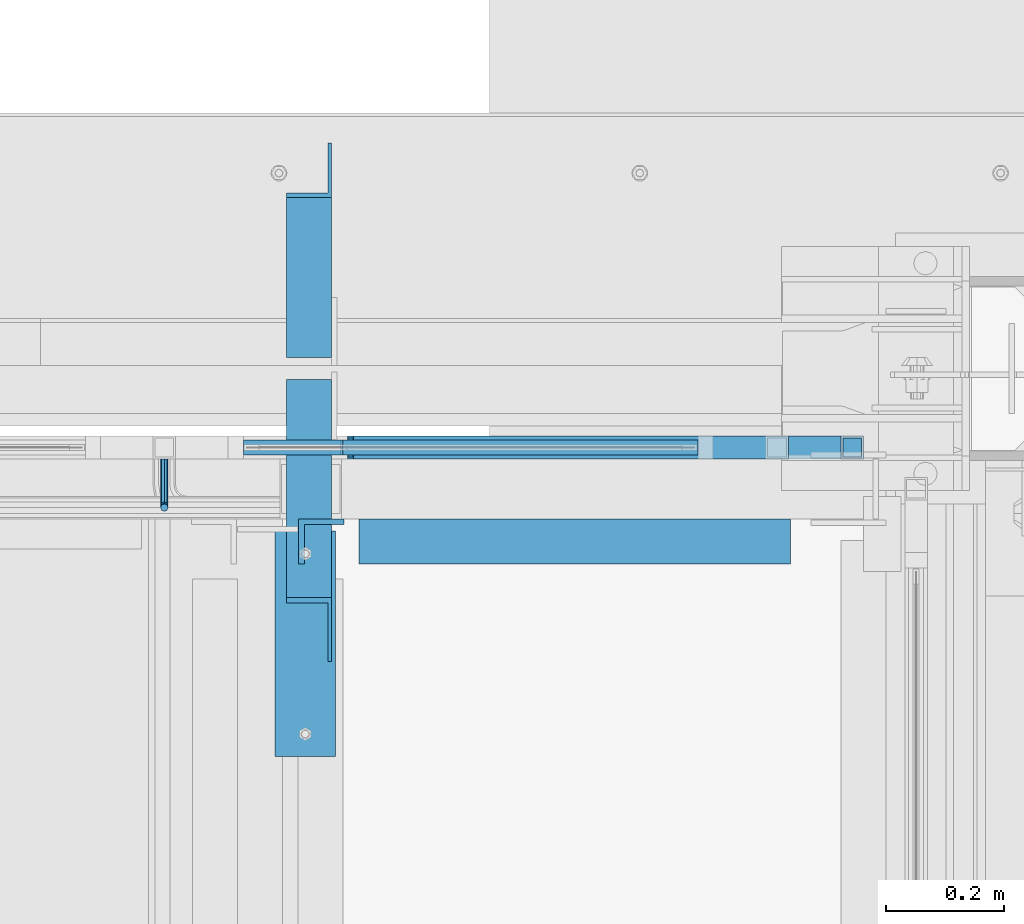
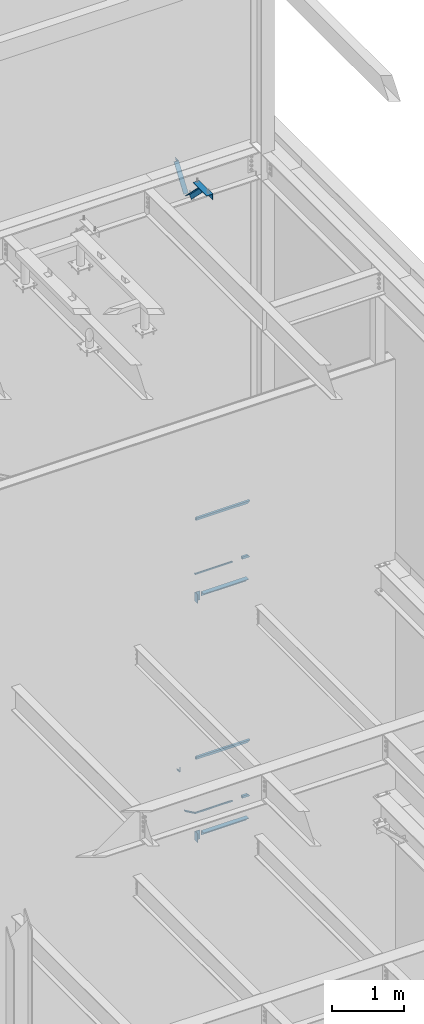
# One storey, part 951 of 1179: 10 beams, 5 members, 7 elements without a shape of their own.
"""IFC2X3 building model written with IfcOpenShell, lengths in millimetres."""

from ifc_helpers import new_model, si_unit, frame, origin_with_axes, place, context, subcontext, project, spatial, faceted_brep, material, type_object, element, aggregate, save


model = new_model("IFC2X3")

# Units and contexts
model_context = context("Model", 3, precision=1e-05, world=origin_with_axes())
body_context = subcontext(model_context, "Body", "Model", "MODEL_VIEW")
ifc_project = project(units=[si_unit("LENGTHUNIT", "METRE", prefix="MILLI"), si_unit("AREAUNIT", "SQUARE_METRE"), si_unit("VOLUMEUNIT", "CUBIC_METRE"), si_unit("MASSUNIT", "GRAM", prefix="KILO"), si_unit("TIMEUNIT", "SECOND"), si_unit("PLANEANGLEUNIT", "RADIAN"), si_unit("SOLIDANGLEUNIT", "STERADIAN"), si_unit("THERMODYNAMICTEMPERATUREUNIT", "DEGREE_CELSIUS"), si_unit("LUMINOUSINTENSITYUNIT", "LUMEN")], contexts=[model_context])

# Site, building, storey
site_placement = place(None, origin_with_axes())
site = spatial("IfcSite", under=ifc_project, at=site_placement, CompositionType="ELEMENT")
building_placement = place(site_placement, origin_with_axes())
building = spatial("IfcBuilding", under=site, at=building_placement, Name="Undefined", CompositionType="ELEMENT")
storey_placement = place(building_placement, origin_with_axes())
storey = spatial("IfcBuildingStorey", under=building, at=storey_placement, Name="Undefined", CompositionType="ELEMENT", Elevation=0.0)

# Assembly, member
assembly_1_placement = place(storey_placement, origin_with_axes())
assembly_1 = element("IfcElementAssembly", 1, at=assembly_1_placement, inside=storey, Name="GUARDRAIL", AssemblyPlace="NOTDEFINED", PredefinedType="RIGID_FRAME")
ifc_material_1 = material()
member_type_1 = type_object("IfcMemberType", Name="HSS1-1/2X1-1/2X1/8", PredefinedType="NOTDEFINED")
member_1_placement = place(assembly_1_placement, frame((23879.17500153, 41065.4499993604, 6337.29999924757), z_axis=(0.0, -1.0, 0.0), x_axis=(1.0, 0.0, 0.0)))
member_1 = element("IfcMember", 2, at=member_1_placement, type_object=member_type_1, material=ifc_material_1, Name="BOTTOM_RAIL", ObjectType="HSS1-1/2X1-1/2X1/8", context=body_context, shape_type="Brep", body=[
    faceted_brep([(19.0499999999993, -19.0499992349996, 19.0500001223481), (19.0499999999993, 19.0499992349996, 19.0499992350015), (19.0499999999993, 19.0499992349996, -19.0499992350015), (19.0499999999993, -19.0499992349996, -19.0499992350015), (19.0499999999993, -15.8749992829999, 15.874999282998), (19.0499999999993, -15.8749992829999, -15.874999282998), (19.0499999999993, 15.8749992829999, -15.874999282998), (19.0499999999993, 15.8749992829999, 15.874999282998), (107.949999235003, 19.0499992349996, -19.0499992350015), (146.049997705006, -19.0499992349996, -19.0499992350015), (146.049997705006, -19.0499992349996, 19.0499992350015), (107.949999235003, 19.0499992349996, 19.0499992350015), (142.874997753006, -15.8749992829999, 15.874999282998), (111.124999187006, 15.8749992829999, 15.874999282998), (111.124999187006, 15.8749992829999, -15.874999282998), (142.874997753006, -15.8749992829999, -15.874999282998)], [[[0, 1, 2, 3], [4, 5, 6, 7]], [[8, 9, 3, 2]], [[9, 10, 0, 3]], [[10, 11, 1, 0]], [[11, 8, 2, 1]], [[10, 9, 8, 11], [12, 13, 14, 15]], [[13, 12, 4, 7]], [[14, 13, 7, 6]], [[15, 14, 6, 5]], [[12, 15, 5, 4]]]),
])

# Assembly, members, beam
assembly_2_placement = place(storey_placement, origin_with_axes())
assembly_2 = element("IfcElementAssembly", 3, at=assembly_2_placement, inside=storey, Name="GUARDRAIL", AssemblyPlace="NOTDEFINED", PredefinedType="RIGID_FRAME")
member_2_placement = place(assembly_2_placement, frame((23879.1750021424, 41065.4499993604, 2263.77499922779), z_axis=(0.0, -1.0, 0.0), x_axis=(1.0, 0.0, 0.0)))
member_2 = element("IfcMember", 4, at=member_2_placement, type_object=member_type_1, material=ifc_material_1, Name="BOTTOM_RAIL", ObjectType="HSS1-1/2X1-1/2X1/8", context=body_context, shape_type="Brep", body=[
    faceted_brep([(19.0499999999993, -19.0499992349996, 19.0500001223481), (19.0499999999993, 19.0499992349996, 19.0499992350015), (19.0499999999993, 19.0499992349996, -19.0499992350015), (19.0499999999993, -19.0499992349996, -19.0499992350015), (19.0499999999993, -15.8749992829999, 15.874999282998), (19.0499999999993, -15.8749992829999, -15.874999282998), (19.0499999999993, 15.8749992829999, -15.874999282998), (19.0499999999993, 15.8749992829999, 15.874999282998), (107.949999235003, 19.0499992349996, -19.0499992350015), (146.049997705006, -19.0499992349996, -19.0499992350015), (146.049997705006, -19.0499992349996, 19.0499992350015), (107.949999235003, 19.0499992349996, 19.0499992350015), (142.874997753006, -15.8749992829999, 15.874999282998), (111.124999187006, 15.8749992829999, 15.874999282998), (111.124999187006, 15.8749992829999, -15.874999282998), (142.874997753006, -15.8749992829999, -15.874999282998)], [[[0, 1, 2, 3], [4, 5, 6, 7]], [[8, 9, 3, 2]], [[9, 10, 0, 3]], [[10, 11, 1, 0]], [[11, 8, 2, 1]], [[10, 9, 8, 11], [12, 13, 14, 15]], [[13, 12, 4, 7]], [[14, 13, 7, 6]], [[15, 14, 6, 5]], [[12, 15, 5, 4]]]),
])
ifc_material_2 = material(Name="STEEL/A36")
beam_type_1 = type_object("IfcBeamType", PredefinedType="NOTDEFINED")
beam_1_placement = place(assembly_2_placement, frame((22844.1248872979, 41046.3999992326, 3115.90434858127), z_axis=(0.0, 0.0, 1.0), x_axis=(0.0, -1.0, 0.0)))
beam_1 = element("IfcBeam", 5, at=beam_1_placement, type_object=beam_type_1, material=ifc_material_2, Name="BRACKET", context=body_context, shape_type="Brep", body=[
    faceted_brep([(0.0, -4.49012806053361, 4.49012806053452), (0.0, 0.0, 6.34999999999991), (0.0, 4.49012806053361, 4.49012806053452), (0.0, 6.34999999999854, 0.0), (0.0, 4.49012806053361, -4.49012806053452), (0.0, 0.0, -6.34999999999991), (0.0, -4.49012806053361, -4.49012806053452), (0.0, -6.34999999999854, 0.0), (69.849999425729, 0.0, -6.34999999999991), (69.849999425729, -4.49012806053361, -4.49012806053452), (69.849999425729, -6.34999999999854, 0.0), (69.849999425729, -4.49012806053361, 4.49012806053452), (69.849999425729, 0.0, 6.34999999999991), (69.849999425729, 4.49012806053361, 4.49012806053452), (69.849999425729, 6.34999999999854, 0.0), (69.849999425729, 4.49012806053361, -4.49012806053452), (78.445063360632, 4.49012806053361, -2.18708762028064), (79.3749993303718, 0.0, -3.79778396764323), (78.445063360632, -4.49012806053361, -2.18708762028064), (76.1999993303689, -6.34999999999854, 1.70147734638658), (73.9549353000984, -4.49012806053361, 5.59004231305425), (73.024999330366, 0.0, 7.20073866041639), (73.9549353000984, 4.49012806053361, 5.59004231305425), (76.1999993303689, 6.34999999999854, 1.70147734638658), (80.8485218886053, 6.34999999999854, 6.34999990462893), (84.7370868552753, 4.49012806053361, 4.10493587436031), (76.9599569219426, 4.49012806053361, 8.59506393489755), (75.3492605745778, 0.0, 9.52499990463093), (76.9599569219426, -4.49012806053361, 8.59506393489755), (80.8485218886053, -6.34999999999854, 6.34999990462893), (84.7370868552753, -4.49012806053361, 4.10493587436031), (86.3477832026401, 0.0, 3.17499990462693), (87.0401272955278, 4.49012806053361, 12.6999998092651), (88.8999992349927, 0.0, 12.6999998092651), (82.5499992349942, 6.34999999999854, 12.6999998092651), (78.0598711744606, 4.49012806053361, 12.6999998092651), (76.1999992349956, 0.0, 12.6999998092651), (78.0598711744606, -4.49012806053361, 12.6999998092651), (82.5499992349942, -6.34999999999854, 12.6999998092651), (87.0401272955278, -4.49012806053361, 12.6999998092651), (88.8999992349927, 0.0, 76.2000000000003), (87.0401272908275, -4.49012806053361, 78.7997529672102), (82.5499992302939, -6.34999999999854, 79.8766059046975), (78.0598711697603, -4.49012806053361, 78.7997529672102), (76.1999992349956, 0.0, 76.2000000000003), (78.0598711697603, 4.49012806053361, 73.6002470344774), (82.5499992302939, 6.34999999999854, 72.5233940969902), (87.0401272908275, 4.49012806053361, 73.6002470344774)], [[[0, 1, 2, 3, 4, 5, 6, 7]], [[6, 5, 8, 9]], [[7, 6, 9, 10]], [[0, 7, 10, 11]], [[1, 0, 11, 12]], [[2, 1, 12, 13]], [[3, 2, 13, 14]], [[4, 3, 14, 15]], [[5, 4, 15, 8]], [[8, 15, 16, 17]], [[9, 8, 17, 18]], [[10, 9, 18, 19]], [[11, 10, 19, 20]], [[12, 11, 20, 21]], [[13, 12, 21, 22]], [[14, 13, 22, 23]], [[15, 14, 23, 16]], [[23, 24, 25, 16]], [[22, 26, 24, 23]], [[21, 27, 26, 22]], [[20, 28, 27, 21]], [[19, 29, 28, 20]], [[18, 30, 29, 19]], [[17, 31, 30, 18]], [[16, 25, 31, 17]], [[25, 32, 33, 31]], [[24, 34, 32, 25]], [[26, 35, 34, 24]], [[27, 36, 35, 26]], [[28, 37, 36, 27]], [[29, 38, 37, 28]], [[30, 39, 38, 29]], [[31, 33, 39, 30]], [[39, 33, 40, 41]], [[38, 39, 41, 42]], [[37, 38, 42, 43]], [[36, 37, 43, 44]], [[35, 36, 44, 45]], [[34, 35, 45, 46]], [[32, 34, 46, 47]], [[33, 32, 47, 40]], [[46, 45, 44, 43, 42, 41, 40, 47]]]),
])
member_type_2 = type_object("IfcMemberType", PredefinedType="NOTDEFINED")
member_3_placement = place(assembly_2_placement, frame((22964.7748872955, 41065.4499993604, 2354.60023139392), z_axis=(0.0, -1.0, 0.0), x_axis=(0.86540914081268, 0.0, -0.501065882891521)))
member_3 = element("IfcMember", 6, at=member_3_placement, type_object=member_type_2, material=ifc_material_2, Name="BOTTOM_RAIL", context=body_context, shape_type="Brep", body=[
    faceted_brep([(10.998533752896, 6.34999999999854, -12.6999999999971), (10.998533752896, 6.34999999999854, 12.6999999999971), (204.904350792844, 6.35000000008768, 12.6999999999971), (204.904350792844, 6.35000000008768, -12.6999999999971), (18.3517455606161, -6.34999999998945, 12.6999999999971), (208.315686455331, -6.34999999990214, 12.6999999999971), (18.3517455606161, -6.34999999998945, -12.6999999999971), (208.315686455331, -6.34999999990214, -12.6999999999971)], [[[0, 1, 2, 3]], [[1, 4, 5, 2]], [[4, 6, 7, 5]], [[6, 0, 3, 7]], [[5, 7, 3, 2]], [[6, 4, 1, 0]]]),
])

# Beam
beam_type_2 = type_object("IfcBeamType", Name="HSS1-1/2X1-1/2X1/8", PredefinedType="NOTDEFINED")
beam_2_placement = place(assembly_1_placement, frame((23158.450001638, 41065.4499992401, 7258.04999918865), z_axis=(0.0, 0.0, 1.0), x_axis=(1.0, 0.0, 0.0)))
beam_2 = element("IfcBeam", 7, at=beam_2_placement, type_object=beam_type_2, material=ifc_material_1, Name="TOP_RAIL", ObjectType="HSS1-1/2X1-1/2X1/8", context=body_context, shape_type="Brep", body=[
    faceted_brep([(-4.2917924263129, 15.874999282998, -15.8749992829908), (-4.2917924263129, -15.874999282998, -15.8749992829908), (831.849999078982, -15.874999282998, -15.8749992829999), (831.849999078982, 15.874999282998, -15.8749992829999), (4.29179243916951, -15.874999282998, 15.8749992829889), (863.599997644982, -15.874999282998, 15.8749992829999), (4.29179243916951, 15.874999282998, 15.8749992829889), (863.599997644982, 15.874999282998, 15.8749992829999), (-5.15015093865441, 19.0499992350015, -19.049999234986), (5.15015095151102, 19.0499992350015, 19.0499992349869), (866.774997596982, 19.0499992350015, 19.0499992349996), (828.674999126979, 19.0499992350015, -19.0499992349996), (5.15015095151102, -19.0499992350015, 19.0499992349869), (866.774997596982, -19.0499992350015, 19.0499992349996), (-5.15015093865441, -19.0499992350015, -19.049999234986), (828.674999126979, -19.0499992350015, -19.0499992349996)], [[[0, 1, 2, 3]], [[1, 4, 5, 2]], [[4, 6, 7, 5]], [[6, 0, 3, 7]], [[8, 9, 10, 11]], [[9, 12, 13, 10]], [[12, 14, 15, 13]], [[14, 8, 11, 15]], [[13, 15, 11, 10], [5, 7, 3, 2]], [[14, 12, 9, 8], [6, 4, 1, 0]]]),
])

beam_3_placement = place(assembly_2_placement, frame((23158.450001638, 41065.4499992401, 3184.52499917608), z_axis=(0.0, 0.0, 1.0), x_axis=(1.0, 0.0, 0.0)))
beam_3 = element("IfcBeam", 8, at=beam_3_placement, type_object=beam_type_2, material=ifc_material_1, Name="TOP_RAIL", ObjectType="HSS1-1/2X1-1/2X1/8", context=body_context, shape_type="Brep", body=[
    faceted_brep([(-4.26416944230368, 15.874999282998, -15.8749992829999), (-4.26416944230368, -15.874999282998, -15.8749992829999), (831.849999078982, -15.874999282998, -15.8749992829999), (831.849999078982, 15.874999282998, -15.8749992829999), (4.2641693228652, -15.874999282998, 15.8749992829999), (863.599997644982, -15.874999282998, 15.8749992829999), (4.2641693228652, 15.874999282998, 15.8749992829999), (863.599997644982, 15.874999282998, 15.8749992829999), (-5.11700334444686, 19.0499992350015, -19.0499992350001), (5.11700322500474, 19.0499992350015, 19.0499992350001), (866.774997596982, 19.0499992350015, 19.0499992349996), (828.674999126979, 19.0499992350015, -19.0499992349996), (5.11700322500474, -19.0499992350015, 19.0499992350001), (866.774997596982, -19.0499992350015, 19.0499992349996), (-5.11700334444686, -19.0499992350015, -19.0499992350001), (828.674999126979, -19.0499992350015, -19.0499992349996)], [[[0, 1, 2, 3]], [[1, 4, 5, 2]], [[4, 6, 7, 5]], [[6, 0, 3, 7]], [[8, 9, 10, 11]], [[9, 12, 13, 10]], [[12, 14, 15, 13]], [[14, 8, 11, 15]], [[13, 15, 11, 10], [5, 7, 3, 2]], [[14, 12, 9, 8], [6, 4, 1, 0]]]),
])

# Assembly, beam
assembly_3_placement = place(storey_placement, origin_with_axes())
assembly_3 = element("IfcElementAssembly", 9, at=assembly_3_placement, inside=storey, Name="STAIR", AssemblyPlace="NOTDEFINED", PredefinedType="RIGID_FRAME")
beam_type_3 = type_object("IfcBeamType", Name="L3X3X3/8", PredefinedType="NOTDEFINED")
beam_4_placement = place(assembly_3_placement, frame((23109.2375003346, 40906.6999999995, 2038.35010000017), z_axis=(1.0, 0.0, 0.0), x_axis=(0.0, 0.0, -1.0)))
beam_4 = element("IfcBeam", 10, at=beam_4_placement, type_object=beam_type_3, material=ifc_material_2, Name="ANGLE", ObjectType="L3X3X3/8", context=body_context, shape_type="Brep", body=[
    faceted_brep([(0.0, 38.0999999999985, -38.0999999999999), (0.0, 38.0999999999985, 38.0999999999999), (152.400000000001, 38.0999999999985, 38.0999999999999), (152.400000000001, 38.0999999999985, -38.0999999999999), (0.0, 28.5750000000007, 38.0999999999999), (152.400000000001, 28.5750000000007, 38.0999999999999), (0.0, 28.5750000000007, -28.575), (152.400000000001, 28.5750000000007, -28.575), (0.0, -38.0999999999985, -28.575), (152.400000000001, -38.0999999999985, -28.575), (0.0, -38.0999999999985, -38.0999999999999), (152.400000000001, -38.0999999999985, -38.0999999999999)], [[[0, 1, 2, 3]], [[1, 4, 5, 2]], [[4, 6, 7, 5]], [[6, 8, 9, 7]], [[8, 10, 11, 9]], [[10, 0, 3, 11]], [[5, 7, 9, 11, 3, 2]], [[10, 8, 6, 4, 1, 0]]]),
])

# Assembly, beams
assembly_4_placement = place(storey_placement, origin_with_axes())
assembly_4 = element("IfcElementAssembly", 11, at=assembly_4_placement, inside=storey, Name="STAIR", AssemblyPlace="NOTDEFINED", PredefinedType="RIGID_FRAME")
beam_5_placement = place(assembly_4_placement, frame((23109.2374999835, 40906.7, 6112.47000099708), z_axis=(1.0, 0.0, 0.0), x_axis=(0.0, 0.0, -1.0)))
beam_5 = element("IfcBeam", 12, at=beam_5_placement, type_object=beam_type_3, material=ifc_material_2, Name="ANGLE", ObjectType="L3X3X3/8", context=body_context, shape_type="Brep", body=[
    faceted_brep([(0.0, 38.0999999999985, -38.0999999999999), (0.0, 38.0999999999985, 38.0999999999999), (152.400000000001, 38.0999999999985, 38.0999999999999), (152.400000000001, 38.0999999999985, -38.0999999999999), (0.0, 28.5750000000007, 38.0999999999999), (152.400000000001, 28.5750000000007, 38.0999999999999), (0.0, 28.5750000000007, -28.575), (152.400000000001, 28.5750000000007, -28.575), (0.0, -38.0999999999985, -28.575), (152.400000000001, -38.0999999999985, -28.575), (0.0, -38.0999999999985, -38.0999999999999), (152.400000000001, -38.0999999999985, -38.0999999999999)], [[[0, 1, 2, 3]], [[1, 4, 5, 2]], [[4, 6, 7, 5]], [[6, 8, 9, 7]], [[8, 10, 11, 9]], [[10, 0, 3, 11]], [[5, 7, 9, 11, 3, 2]], [[10, 8, 6, 4, 1, 0]]]),
])
beam_type_4 = type_object("IfcBeamType", Name="L3X3X1/4", PredefinedType="NOTDEFINED")
beam_6_placement = place(assembly_4_placement, frame((23172.7374999277, 40906.6999999994, 6051.55), z_axis=(0.0, -1.0, 0.0), x_axis=(1.0, 0.0, 0.0)))
beam_6 = element("IfcBeam", 13, at=beam_6_placement, type_object=beam_type_4, material=ifc_material_2, Name="ANGLE", ObjectType="L3X3X1/4", context=body_context, shape_type="Brep", body=[
    faceted_brep([(0.0, 38.0999999999985, -38.0999999999999), (0.0, 38.0999999999985, 38.0999999999999), (729.059375016303, 38.0999999999985, 38.1000000000004), (729.059375016303, 38.0999999999985, -38.1000000000004), (0.0, 31.75, 38.1000000000004), (729.059375016303, 31.75, 38.1000000000004), (0.0, 31.75, -31.75), (729.059375016303, 31.75, -31.75), (0.0, -38.0999999999985, -31.75), (729.059375016303, -38.0999999999985, -31.75), (0.0, -38.0999999999985, -38.0999999999999), (729.059375016303, -38.0999999999985, -38.1000000000004)], [[[0, 1, 2, 3]], [[1, 4, 5, 2]], [[4, 6, 7, 5]], [[6, 8, 9, 7]], [[8, 10, 11, 9]], [[10, 0, 3, 11]], [[5, 7, 9, 11, 3, 2]], [[10, 8, 6, 4, 1, 0]]]),
])
aggregate(assembly_4, [beam_6, beam_5])

# Beam
beam_7_placement = place(assembly_3_placement, frame((23172.737500342, 40906.6999999994, 1978.025), z_axis=(0.0, -1.0, 0.0), x_axis=(1.0, 0.0, 0.0)))
beam_7 = element("IfcBeam", 14, at=beam_7_placement, type_object=beam_type_4, material=ifc_material_2, Name="ANGLE", ObjectType="L3X3X1/4", context=body_context, shape_type="Brep", body=[
    faceted_brep([(0.0, 38.0999999999985, -38.0999999999999), (0.0, 38.0999999999985, 38.0999999999999), (729.059375016303, 38.0999999999985, 38.1000000000004), (729.059375016303, 38.0999999999985, -38.1000000000004), (0.0, 31.75, 38.1000000000004), (729.059375016303, 31.75, 38.1000000000004), (0.0, 31.75, -31.75), (729.059375016303, 31.75, -31.75), (0.0, -38.0999999999985, -31.75), (729.059375016303, -38.0999999999985, -31.75), (0.0, -38.0999999999985, -38.0999999999999), (729.059375016303, -38.0999999999985, -38.1000000000004)], [[[0, 1, 2, 3]], [[1, 4, 5, 2]], [[4, 6, 7, 5]], [[6, 8, 9, 7]], [[8, 10, 11, 9]], [[10, 0, 3, 11]], [[5, 7, 9, 11, 3, 2]], [[10, 8, 6, 4, 1, 0]]]),
])

aggregate(assembly_3, [beam_4, beam_7])

beam_type_5 = type_object("IfcBeamType", PredefinedType="NOTDEFINED")
beam_8_placement = place(assembly_1_placement, frame((23144.0913325789, 41065.449999241, 6324.6000000122), z_axis=(0.0, -1.0, 0.0), x_axis=(1.0, 0.0, 0.0)))
beam_8 = element("IfcBeam", 15, at=beam_8_placement, type_object=beam_type_5, material=ifc_material_2, Name="BOTTOM_RAIL", context=body_context, shape_type="Brep", body=[
    faceted_brep([(601.733669716123, -6.35000000000036, 12.6999999999971), (601.733669716123, -6.35000000000036, -12.6999999999971), (601.733669716123, 6.35000000000036, -12.6999999999971), (601.733669716123, 6.35000000000036, 12.6999999999971), (-1.7167171036599, -6.35000000000036, -12.6999999999971), (-1.7167171036599, -6.35000000000036, 12.6999999999971), (1.71671700343359, 6.35000000000036, 12.6999999999971), (1.71671700343359, 6.35000000000036, -12.6999999999971)], [[[0, 1, 2, 3]], [[4, 5, 6, 7]], [[6, 5, 0, 3]], [[7, 6, 3, 2]], [[4, 7, 2, 1]], [[5, 4, 1, 0]]]),
])

aggregate(assembly_1, [member_1, beam_8, beam_2])

beam_9_placement = place(assembly_2_placement, frame((23143.5770859921, 41065.449999241, 2251.075), z_axis=(0.0, -1.0, 0.0), x_axis=(1.0, 0.0, 0.0)))
beam_9 = element("IfcBeam", 16, at=beam_9_placement, type_object=beam_type_5, material=ifc_material_2, Name="BOTTOM_RAIL", context=body_context, shape_type="Brep", body=[
    faceted_brep([(602.247916915268, -6.34999999999991, 12.6999999999971), (602.247916915268, -6.34999999999991, -12.6999999999971), (602.247916915268, 6.34999999999991, -12.6999999999971), (602.247916915268, 6.34999999999991, 12.6999999999971), (-1.70566781896196, -6.34999999999991, -12.6999999999971), (-1.70566781896196, -6.34999999999991, 12.6999999999971), (1.7056678280278, 6.34999999999991, 12.6999999999971), (1.7056678280278, 6.34999999999991, -12.6999999999971)], [[[0, 1, 2, 3]], [[4, 5, 6, 7]], [[6, 5, 0, 3]], [[7, 6, 3, 2]], [[4, 7, 2, 1]], [[5, 4, 1, 0]]]),
])

aggregate(assembly_2, [member_2, member_3, beam_1, beam_9, beam_3])

# Assembly, member
assembly_5_placement = place(storey_placement, origin_with_axes())
assembly_5 = element("IfcElementAssembly", 17, at=assembly_5_placement, inside=storey, Name="ANGLE", AssemblyPlace="NOTDEFINED", PredefinedType="RIGID_FRAME")
member_type_3 = type_object("IfcMemberType", Name="L3X3X1/4", PredefinedType="NOTDEFINED")
member_4_placement = place(assembly_5_placement, frame((23088.6, 40704.7386537875, 13150.1502196524), z_axis=(0.0, -0.706388288025418, -0.707824545025474), x_axis=(0.0, 0.707824545025473, -0.706388288025419)))
member_4 = element("IfcMember", 18, at=member_4_placement, type_object=member_type_3, material=ifc_material_2, Name="ANGLE", ObjectType="L3X3X1/4", context=body_context, shape_type="Brep", body=[
    faceted_brep([(634.184990526992, 31.75, 38.0999999999767), (634.184990526996, 31.75, -31.7499999999636), (634.184990526996, -38.0999999999985, -31.7499999999636), (634.184990526996, -38.0999999999985, -38.0999999999549), (634.184990526996, 38.0999999999985, -38.0999999999549), (634.184990526992, 38.0999999999985, 38.0999999999767), (113.596638248473, -38.0999999999985, -38.0999999999549), (113.596638248473, 38.0999999999985, -38.0999999999549), (37.2417053522113, 38.0999999999985, 38.0999999999694), (37.2417053522113, 31.75, 38.0999999999694), (107.233727173789, 31.75, -31.7499999999709), (107.233727173789, -38.0999999999985, -31.7499999999709)], [[[0, 1, 2, 3, 4, 5]], [[4, 3, 6, 7]], [[5, 4, 7, 8]], [[0, 5, 8, 9]], [[1, 0, 9, 10]], [[2, 1, 10, 11]], [[3, 2, 11, 6]], [[10, 9, 8, 7, 6, 11]]]),
])
aggregate(assembly_5, [member_4])

assembly_6_placement = place(storey_placement, origin_with_axes())
assembly_6 = element("IfcElementAssembly", 19, at=assembly_6_placement, inside=storey, Name="ANGLE", AssemblyPlace="NOTDEFINED", PredefinedType="RIGID_FRAME")
member_5_placement = place(assembly_6_placement, frame((23088.6, 41248.3636551321, 12707.4244380128), z_axis=(0.0, 0.821716663099518, -0.569896241069015), x_axis=(0.0, 0.569896241069016, 0.821716663099518)))
member_5 = element("IfcMember", 20, at=member_5_placement, type_object=member_type_3, material=ifc_material_2, Name="ANGLE", ObjectType="L3X3X1/4", context=body_context, shape_type="Brep", body=[
    faceted_brep([(0.0, -38.0999999999985, -38.0999999999999), (0.0, -38.0999999999985, -31.75), (0.0, 31.75, -31.75), (0.0, 31.75, 38.1000000000004), (0.0, 38.0999999999985, 38.0999999999999), (0.0, 38.0999999999985, -38.0999999999999), (527.418547333735, 31.75, 38.0999999993364), (527.418547333735, 38.1000000000004, 38.0999999993364), (474.570533511644, 38.1000000000004, -38.1000000006607), (474.570533511644, -38.1000000000004, -38.1000000006607), (478.974534663488, -38.1000000000004, -31.7500000006621), (478.974534663488, 31.75, -31.7500000006621)], [[[0, 1, 2, 3, 4, 5]], [[4, 3, 6, 7]], [[5, 4, 7, 8]], [[0, 5, 8, 9]], [[1, 0, 9, 10]], [[2, 1, 10, 11]], [[3, 2, 11, 6]], [[10, 9, 8, 7, 6, 11]]]),
])
aggregate(assembly_6, [member_5])

# Assembly, beam
assembly_7_placement = place(storey_placement, origin_with_axes())
assembly_7 = element("IfcElementAssembly", 21, at=assembly_7_placement, inside=storey, Name="ANGLE", AssemblyPlace="NOTDEFINED", PredefinedType="RIGID_FRAME")
beam_type_6 = type_object("IfcBeamType", Name="L4X4X1/4", PredefinedType="NOTDEFINED")
beam_10_placement = place(assembly_7_placement, frame((23082.249999998, 40924.162499953, 13068.3), z_axis=(-1.0, 0.0, 0.0), x_axis=(0.0, -1.0, 0.0)))
beam_10 = element("IfcBeam", 22, at=beam_10_placement, type_object=beam_type_6, material=ifc_material_2, Name="ANGLE", ObjectType="L4X4X1/4", context=body_context, shape_type="Brep", body=[
    faceted_brep([(1.90993887372315e-11, 50.8000000000002, -50.8000000000002), (1.90993887372315e-11, 50.8000000000002, 50.8000000000002), (381.0, 50.8000000000002, 50.7999999999993), (381.0, 50.8000000000002, -50.7999999999993), (0.0, 44.4500000000007, 50.8000000000002), (381.0, 44.4499999999998, 50.7999999999993), (0.0, 44.4500000000007, -44.4499999999998), (381.0, 44.4499999999998, -44.4500000000007), (0.0, -50.7999999999993, -44.4499999999998), (381.0, -50.8000000000002, -44.4500000000007), (-1.81898940354586e-11, -50.7999999999997, -50.8000000000002), (381.0, -50.8000000000002, -50.7999999999993)], [[[0, 1, 2, 3]], [[1, 4, 5, 2]], [[4, 6, 7, 5]], [[6, 8, 9, 7]], [[8, 10, 11, 9]], [[10, 0, 3, 11]], [[5, 7, 9, 11, 3, 2]], [[10, 8, 6, 4, 1, 0]]]),
])
aggregate(assembly_7, [beam_10])

save(model, "model.ifc")
